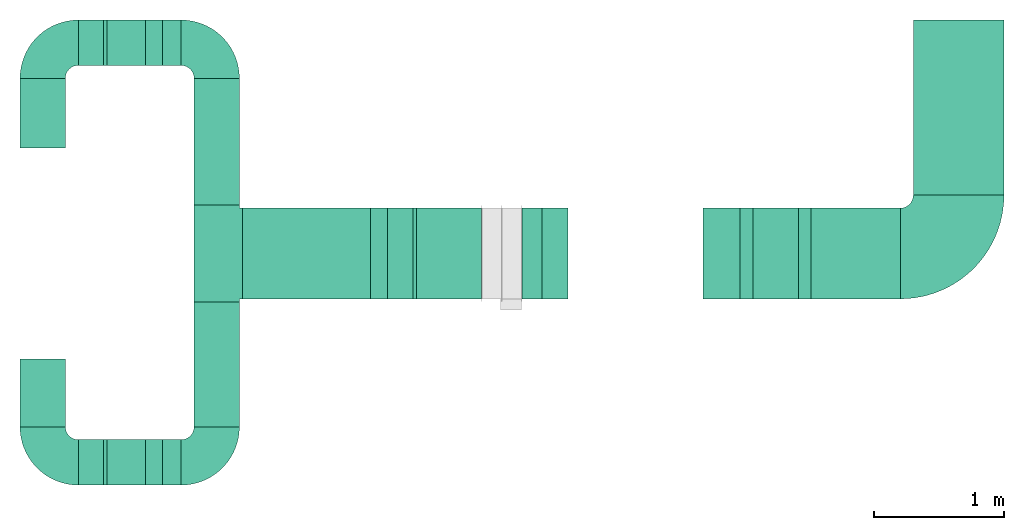
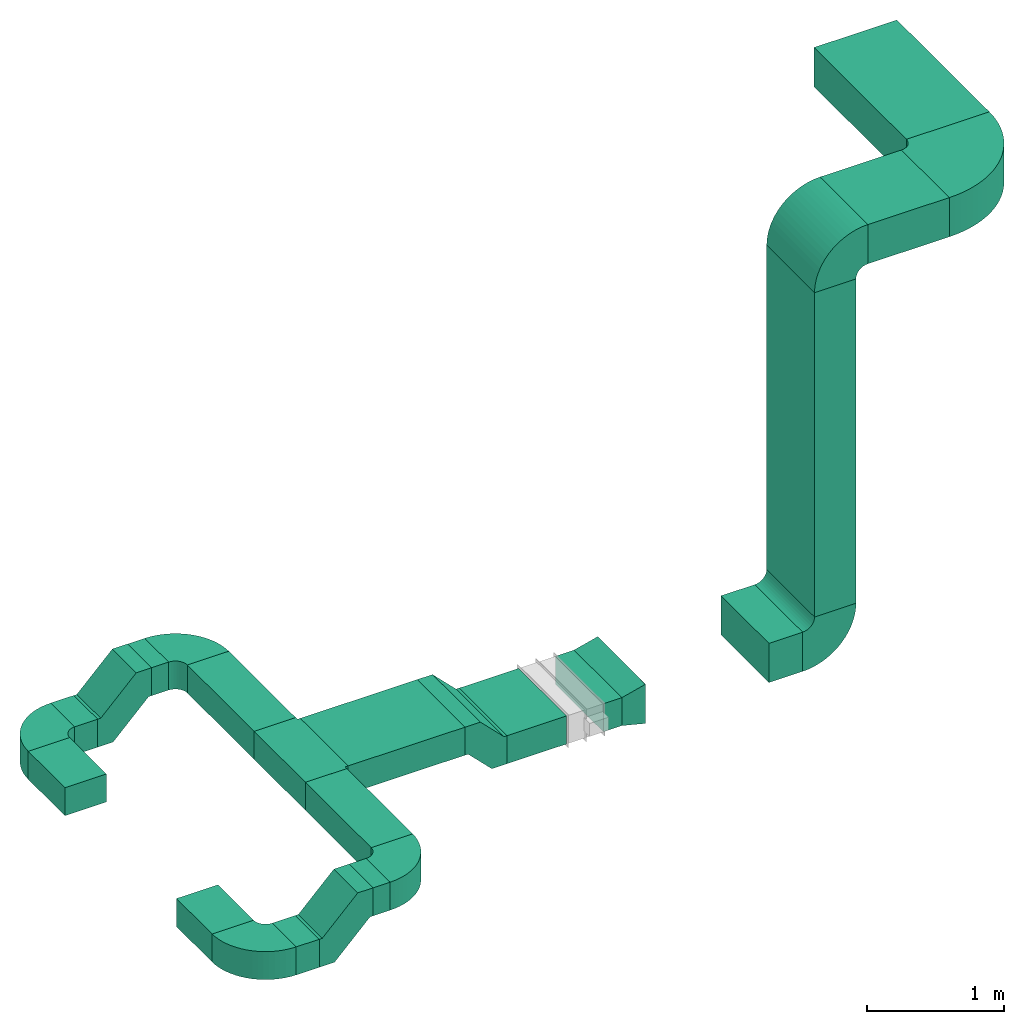
# One storey, part 1 of 2: 15 flow segments, 12 flow fittings.
"""IFC2X3 building model written with IfcOpenShell, lengths in millimetres."""

import ifcopenshell
import ifcopenshell.guid

model = None  # the IFC model being written
_history = None  # IfcOwnerHistory: only IFC2X3 demands one
_inside = {}  # id of a spatial element -> (the spatial element, [elements in it])
_under = {}  # id of a project, library or spatial element -> (it, [spatial elements below it])
_declared = {}  # id of a project -> (the project, [libraries it declares])
_typed = {}  # id of a type object -> (the type object, [elements of that type])
_made_of = {}  # id of a material, layer set ... -> (it, [elements and type objects made of it])


def new_model(schema):
    """Start an empty IFC model of exactly this schema.

    Asked for "IFC4X3", IfcOpenShell would pick the latest addendum, in which some entities
    have other attributes; the version numbers below select the first issue.
    IFC2X3 requires an IfcOwnerHistory on every rooted entity: one is made here for all.
    """
    global model, _history
    if schema == "IFC4X3":
        model = ifcopenshell.file(schema_version=(4, 3, 0, 0))
    else:
        model = ifcopenshell.file(schema=schema)
    _inside.clear()
    _under.clear()
    _declared.clear()
    _typed.clear()
    _made_of.clear()
    _history = None
    if model.schema == "IFC2X3":
        org = make("IfcOrganization", Name="unknown")
        user = make(
            "IfcPersonAndOrganization",
            ThePerson=make("IfcPerson", FamilyName="unknown"),
            TheOrganization=org,
        )
        app = make(
            "IfcApplication",
            ApplicationDeveloper=org,
            Version="unknown",
            ApplicationFullName="unknown",
            ApplicationIdentifier="unknown",
        )
        _history = make(
            "IfcOwnerHistory",
            OwningUser=user,
            OwningApplication=app,
            ChangeAction="ADDED",
            CreationDate=0,
        )
    return model


def make(cls, **values):
    """One entity of the class cls with the attributes given. An attribute that is None is left unset."""
    return model.create_entity(
        cls, **{name: value for name, value in values.items() if value is not None}
    )


def entity(cls, *values):
    """Any entity or typed value of the class cls, its attributes in the order of the schema. None: left unset."""
    e = model.create_entity(cls)
    for i, value in enumerate(values):
        if value is not None:
            e[i] = value
    return e


def rooted(cls, **values):
    """An entity with a GlobalId (a new one), such as an element, a storey or a relation."""
    return make(cls, GlobalId=ifcopenshell.guid.new(), OwnerHistory=_history, **values)


def si_unit(unit_type, name, prefix=None):
    """IfcSIUnit, for example si_unit("LENGTHUNIT", "METRE", prefix="MILLI")."""
    return make("IfcSIUnit", UnitType=unit_type, Prefix=prefix, Name=name)


def converted_unit(unit_type, name, factor, base, dimensions=None, offset=None):
    """IfcConversionBasedUnit, such as the inch: factor (a typed value) times the base unit."""
    return make(
        "IfcConversionBasedUnit"
        if offset is None
        else "IfcConversionBasedUnitWithOffset",
        ConversionOffset=offset,
        Dimensions=None
        if dimensions is None
        else entity("IfcDimensionalExponents", *dimensions),
        UnitType=unit_type,
        Name=name,
        ConversionFactor=make(
            "IfcMeasureWithUnit", ValueComponent=factor, UnitComponent=base
        ),
    )


def derived_unit(unit_type, elements):
    """IfcDerivedUnit: a product of units, each with its exponent."""
    return make(
        "IfcDerivedUnit",
        Elements=[
            make("IfcDerivedUnitElement", Unit=unit, Exponent=power)
            for unit, power in elements
        ],
        UnitType=unit_type,
    )


def assignment(units):
    """IfcUnitAssignment: the units of a project."""
    return None if units is None else make("IfcUnitAssignment", Units=units)


def point(xyz):
    """IfcCartesianPoint."""
    return None if xyz is None else make("IfcCartesianPoint", Coordinates=xyz)


def direction(xyz):
    """IfcDirection."""
    return None if xyz is None else make("IfcDirection", DirectionRatios=xyz)


def frame(location, z_axis=None, x_axis=None):
    """IfcAxis2Placement3D, a coordinate frame: its origin and axes. An axis left out is left unset."""
    return make(
        "IfcAxis2Placement3D",
        Location=point(location),
        Axis=direction(z_axis),
        RefDirection=direction(x_axis),
    )


def frame_2d(location, x_axis=None):
    """IfcAxis2Placement2D, a coordinate frame in the plane: its origin and x axis."""
    return make(
        "IfcAxis2Placement2D", Location=point(location), RefDirection=direction(x_axis)
    )


def origin():
    """The frame at (0, 0, 0) with its axes left unset."""
    return frame((0.0, 0.0, 0.0))


def origin_2d_with_axis():
    """The frame at (0, 0) in the plane with the x axis (1, 0) written out."""
    return frame_2d((0.0, 0.0), x_axis=(1.0, 0.0))


def place(relative_to, where):
    """IfcLocalPlacement: puts the frame where relative to a parent placement (None: the world)."""
    return make(
        "IfcLocalPlacement", PlacementRelTo=relative_to, RelativePlacement=where
    )


def context(
    kind, dimensions, precision=None, world=None, true_north=None, identifier=None
):
    """IfcGeometricRepresentationContext, for example the 3D "Model" context."""
    return make(
        "IfcGeometricRepresentationContext",
        ContextIdentifier=identifier,
        ContextType=kind,
        CoordinateSpaceDimension=dimensions,
        Precision=precision,
        WorldCoordinateSystem=world,
        TrueNorth=true_north,
    )


def subcontext(parent, identifier, kind, view, scale=None):
    """IfcGeometricRepresentationSubContext, for example "Body" below "Model"."""
    return make(
        "IfcGeometricRepresentationSubContext",
        ContextIdentifier=identifier,
        ContextType=kind,
        ParentContext=parent,
        TargetScale=scale,
        TargetView=view,
    )


def project(units=None, contexts=None):
    """IfcProject with its units and contexts."""
    return rooted(
        "IfcProject",
        Name="project",
        RepresentationContexts=contexts,
        UnitsInContext=assignment(units),
    )


def spatial(cls, under=None, at=None, **own):
    """A site, building, storey or space (cls), placed at a placement, below another one or the project."""
    s = rooted(cls, ObjectPlacement=at, **own)
    if under is not None:
        _under.setdefault(under.id(), (under, []))[1].append(s)
    return s


def polyline(points):
    """IfcPolyline through the points."""
    return make("IfcPolyline", Points=[point(p) for p in points])


def circle_curve(where, radius):
    """IfcCircle in the frame where."""
    return make("IfcCircle", Position=where, Radius=radius)


def parameter(value):
    """IfcParameterValue: where a trimmed curve begins or ends, as a parameter of its basis curve."""
    return model.create_entity("IfcParameterValue", value)


def trimmed(basis, trim1, trim2, sense, master):
    """IfcTrimmedCurve: the piece of a basis curve between two trims."""
    return make(
        "IfcTrimmedCurve",
        BasisCurve=basis,
        Trim1=trim1,
        Trim2=trim2,
        SenseAgreement=sense,
        MasterRepresentation=master,
    )


def segment(curve, same_sense, transition):
    """IfcCompositeCurveSegment."""
    return make(
        "IfcCompositeCurveSegment",
        Transition=transition,
        SameSense=same_sense,
        ParentCurve=curve,
    )


def composite_curve(segments, self_intersect=None):
    """IfcCompositeCurve: segments joined end to end."""
    return make("IfcCompositeCurve", Segments=segments, SelfIntersect=self_intersect)


def profile(cls, at=None, kind="AREA", **sizes):
    """A parametric profile (cls). Its sizes go by their IFC names, for example OverallWidth=200.0."""
    return make(cls, ProfileType=kind, Position=at, **sizes)


def rectangle(**sizes):
    """IfcRectangleProfileDef."""
    return profile("IfcRectangleProfileDef", **sizes)


def outline(outer, holes=None, kind="AREA"):
    """IfcArbitraryClosedProfileDef: a profile drawn as a closed curve; with holes, ...WithVoids."""
    if holes is None:
        return make("IfcArbitraryClosedProfileDef", ProfileType=kind, OuterCurve=outer)
    return make(
        "IfcArbitraryProfileDefWithVoids",
        ProfileType=kind,
        OuterCurve=outer,
        InnerCurves=holes,
    )


def extrude(swept, where, along, depth):
    """IfcExtrudedAreaSolid: the profile swept, set in the frame where, extruded along a direction by depth."""
    return make(
        "IfcExtrudedAreaSolid",
        SweptArea=swept,
        Position=where,
        ExtrudedDirection=direction(along),
        Depth=depth,
    )


def shape(context_of_items, identifier, shape_type, items):
    """IfcShapeRepresentation: the items that make up one representation, for example the "Body"."""
    return make(
        "IfcShapeRepresentation",
        ContextOfItems=context_of_items,
        RepresentationIdentifier=identifier,
        RepresentationType=shape_type,
        Items=items,
    )


def source(mapping_origin, context_of_items, identifier, shape_type, items):
    """IfcRepresentationMap: a shape defined once, which mapped items show again and again."""
    return make(
        "IfcRepresentationMap",
        MappingOrigin=mapping_origin,
        MappedRepresentation=shape(context_of_items, identifier, shape_type, items),
    )


def transform(
    local_origin,
    x_axis=None,
    y_axis=None,
    z_axis=None,
    scale=None,
    scale2=None,
    scale3=None,
    uniform=True,
):
    """IfcCartesianTransformationOperator3D, or its non-uniform kind. x_axis, y_axis, z_axis: its Axis1, 2, 3."""
    if uniform:
        return make(
            "IfcCartesianTransformationOperator3D",
            Axis1=direction(x_axis),
            Axis2=direction(y_axis),
            LocalOrigin=point(local_origin),
            Scale=scale,
            Axis3=direction(z_axis),
        )
    return make(
        "IfcCartesianTransformationOperator3DnonUniform",
        Axis1=direction(x_axis),
        Axis2=direction(y_axis),
        LocalOrigin=point(local_origin),
        Scale=scale,
        Axis3=direction(z_axis),
        Scale2=scale2,
        Scale3=scale3,
    )


def mapped(mapping_source, mapping_target):
    """IfcMappedItem: shows the shape of a source again, moved by a transform."""
    return make(
        "IfcMappedItem", MappingSource=mapping_source, MappingTarget=mapping_target
    )


def material(Name=None, Category=None):
    """IfcMaterial."""
    return make("IfcMaterial", Name=Name, Category=Category)


def made_of(thing, what):
    """Note that an element or type object is made of a material, layer set ...; save() writes the relation."""
    if what is not None:
        _made_of.setdefault(what.id(), (what, []))[1].append(thing)
    return thing


def type_object(cls, material=None, **own):
    """A type object (cls), such as IfcWallType, which elements share."""
    return made_of(rooted(cls, **own), material)


def type_shapes(of_type, sources):
    """Give a type object the sources (RepresentationMaps) that its elements show as mapped items."""
    of_type.RepresentationMaps = sources


def element(
    cls,
    number,
    at=None,
    inside=None,
    cuts=None,
    type_object=None,
    material=None,
    context=None,
    identifier="Body",
    shape_type=None,
    held_by="IfcProductDefinitionShape",
    body=None,
    shapes=None,
    **own,
):
    """One element of the class cls, such as IfcWall. Its Tag is "e" and its number.

    at: its placement. inside: the storey or other place that contains it. cuts: it is an
    opening in that element (IfcRelVoidsElement). A single representation is given by context,
    identifier, shape_type and body (its items); several are given by shapes. held_by: the class
    of the entity that holds the representations. save() writes the other relations.
    """
    e = rooted(cls, Tag="e%d" % number, ObjectPlacement=at, **own)
    if body is not None:
        shapes = [shape(context, identifier, shape_type, body)]
    if shapes is not None:
        e.Representation = make(held_by, Representations=shapes)
    if inside is not None:
        _inside.setdefault(inside.id(), (inside, []))[1].append(e)
    if cuts is not None:
        rooted(
            "IfcRelVoidsElement", RelatingBuildingElement=cuts, RelatedOpeningElement=e
        )
    if type_object is not None:
        _typed.setdefault(type_object.id(), (type_object, []))[1].append(e)
    return made_of(e, material)


def aggregate(whole, parts):
    """IfcRelAggregates: a whole, such as a stair, and the parts it consists of."""
    return rooted("IfcRelAggregates", RelatingObject=whole, RelatedObjects=parts)


def save(model, path):
    """Write the relations noted so far, then the file.

    IfcRelAggregates (storeys below a building ...), IfcRelContainedInSpatialStructure (elements
    in a storey), IfcRelDefinesByType, IfcRelAssociatesMaterial and IfcRelDeclares: one each for
    every whole, place, type object, material and project.
    """
    for whole, parts in _under.values():
        aggregate(whole, parts)
    for where, things in _inside.values():
        rooted(
            "IfcRelContainedInSpatialStructure",
            RelatedElements=things,
            RelatingStructure=where,
        )
    for kind, things in _typed.values():
        rooted("IfcRelDefinesByType", RelatedObjects=things, RelatingType=kind)
    for what, things in _made_of.values():
        rooted("IfcRelAssociatesMaterial", RelatedObjects=things, RelatingMaterial=what)
    for by, libraries in _declared.values():
        rooted("IfcRelDeclares", RelatingContext=by, RelatedDefinitions=libraries)
    model.write(path)


model = new_model("IFC2X3")

# Units and contexts
model_context = context("Model", 3, precision=0.01, world=origin(), true_north=direction((6.12303176911189e-17, 1.0)))
body_context = subcontext(model_context, "Body", "Model", "MODEL_VIEW")
ifc_project = project(units=[si_unit("LENGTHUNIT", "METRE", prefix="MILLI"), si_unit("AREAUNIT", "SQUARE_METRE"), si_unit("VOLUMEUNIT", "CUBIC_METRE"), converted_unit("PLANEANGLEUNIT", "DEGREE", entity("IfcRatioMeasure", 0.0174532925199433), si_unit("PLANEANGLEUNIT", "RADIAN"), dimensions=[0, 0, 0, 0, 0, 0, 0]), si_unit("MASSUNIT", "GRAM", prefix="KILO"), derived_unit("MASSDENSITYUNIT", [(si_unit("MASSUNIT", "GRAM", prefix="KILO"), 1), (si_unit("LENGTHUNIT", "METRE"), -3)]), si_unit("TIMEUNIT", "SECOND"), si_unit("FREQUENCYUNIT", "HERTZ"), si_unit("THERMODYNAMICTEMPERATUREUNIT", "DEGREE_CELSIUS"), derived_unit("THERMALTRANSMITTANCEUNIT", [(si_unit("MASSUNIT", "GRAM", prefix="KILO"), 1), (si_unit("THERMODYNAMICTEMPERATUREUNIT", "KELVIN"), -1), (si_unit("TIMEUNIT", "SECOND"), -3)]), derived_unit("VOLUMETRICFLOWRATEUNIT", [(si_unit("LENGTHUNIT", "METRE"), 3), (si_unit("TIMEUNIT", "SECOND"), -1)]), si_unit("ELECTRICCURRENTUNIT", "AMPERE"), si_unit("ELECTRICVOLTAGEUNIT", "VOLT"), si_unit("POWERUNIT", "WATT"), si_unit("FORCEUNIT", "NEWTON", prefix="KILO"), si_unit("ILLUMINANCEUNIT", "LUX"), si_unit("LUMINOUSFLUXUNIT", "LUMEN"), si_unit("LUMINOUSINTENSITYUNIT", "CANDELA"), derived_unit("USERDEFINED", [(si_unit("MASSUNIT", "GRAM", prefix="KILO"), -1), (si_unit("LENGTHUNIT", "METRE"), -2), (si_unit("TIMEUNIT", "SECOND"), 3), (si_unit("LUMINOUSFLUXUNIT", "LUMEN"), 1)]), derived_unit("LINEARVELOCITYUNIT", [(si_unit("LENGTHUNIT", "METRE"), 1), (si_unit("TIMEUNIT", "SECOND"), -1)]), si_unit("PRESSUREUNIT", "PASCAL"), derived_unit("USERDEFINED", [(si_unit("LENGTHUNIT", "METRE"), -2), (si_unit("MASSUNIT", "GRAM", prefix="KILO"), 1), (si_unit("TIMEUNIT", "SECOND"), -2)])], contexts=[model_context])

# Site, building, storey
site_placement = place(None, origin())
site = spatial("IfcSite", under=ifc_project, at=site_placement, CompositionType="ELEMENT")
building_placement = place(site_placement, origin())
building = spatial("IfcBuilding", under=site, at=building_placement, CompositionType="ELEMENT")
storey_placement = place(building_placement, frame((0.0, 0.0, 16000.0)))
storey = spatial("IfcBuildingStorey", under=building, at=storey_placement, Name="04 Roof", CompositionType="ELEMENT", Elevation=16000.0)

# Flow segments
duct_segment_type = type_object("IfcDuctSegmentType", Name="Rectangular Duct:Air", PredefinedType="NOTDEFINED")
flow_segment_1_placement = place(storey_placement, frame((24455.6615179764, -68016.2395851399, 1110.95052634352)))
element("IfcFlowSegment", 1, at=flow_segment_1_placement, inside=storey, type_object=duct_segment_type, Name="Rectangular Duct:Air", ObjectType="Rectangular Duct:Air", context=body_context, shape_type="SweptSolid", body=[
    extrude(rectangle(XDim=536.322509939068, YDim=349.999999999998, at=frame_2d((-8.64019966684282e-12, 0.0), x_axis=(1.0, 0.0))), frame((175.0, 268.161254969525, 0.0), z_axis=(0.0, 0.0, 1.0), x_axis=(0.0, -1.0, 0.0)), (0.0, 0.0, 1.0), 249.999999999999),
])
flow_segment_2_placement = place(storey_placement, frame((24455.6615179763, -70167.9433547427, 1110.95052634352)))
element("IfcFlowSegment", 2, at=flow_segment_2_placement, inside=storey, type_object=duct_segment_type, Name="Rectangular Duct:Air", ObjectType="Rectangular Duct:Air", context=body_context, shape_type="SweptSolid", body=[
    extrude(rectangle(XDim=521.70376960282, YDim=349.999999999998, at=origin_2d_with_axis()), frame((175.0, 260.85188480141, 0.0), z_axis=(0.0, 0.0, 1.0), x_axis=(0.0, 1.0, 0.0)), (0.0, 0.0, 1.0), 249.999999999999),
])
flow_segment_3_placement = place(storey_placement, frame((24905.6615179764, -67379.9170752009, 1110.95052634352)))
element("IfcFlowSegment", 3, at=flow_segment_3_placement, inside=storey, type_object=duct_segment_type, Name="Rectangular Duct:Air", ObjectType="Rectangular Duct:Air", context=body_context, shape_type="SweptSolid", body=[
    extrude(rectangle(XDim=194.397035506843, YDim=349.999999999998, at=frame_2d((-2.16715534406831e-12, -4.33431068813661e-12), x_axis=(1.0, 0.0))), frame((97.1985177534237, 175.0, 0.0)), (0.0, 0.0, 1.0), 249.999999999999),
])
flow_segment_4_placement = place(storey_placement, frame((24905.6615179763, -70617.9433547427, 1110.95052634352)))
element("IfcFlowSegment", 4, at=flow_segment_4_placement, inside=storey, type_object=duct_segment_type, Name="Rectangular Duct:Air", ObjectType="Rectangular Duct:Air", context=body_context, shape_type="SweptSolid", body=[
    extrude(rectangle(XDim=194.397035506869, YDim=349.999999999998, at=frame_2d((-2.16715534406831e-12, -4.33431068813661e-12), x_axis=(1.0, 0.0))), frame((97.1985177534324, 175.0, 0.0)), (0.0, 0.0, 1.0), 249.999999999999),
])
flow_segment_5_placement = place(storey_placement, frame((25798.4900708518, -70167.9433547427, 1410.95052634352)))
element("IfcFlowSegment", 5, at=flow_segment_5_placement, inside=storey, type_object=duct_segment_type, Name="Rectangular Duct:Air", ObjectType="Rectangular Duct:Air", context=body_context, shape_type="SweptSolid", body=[
    extrude(rectangle(XDim=961.703769602799, YDim=349.999999999998, at=frame_2d((-4.34852154285181e-12, 0.0), x_axis=(1.0, 0.0))), frame((175.0, 480.851884801395, 0.0), z_axis=(0.0, 0.0, 1.0), x_axis=(0.0, -1.0, 0.0)), (0.0, 0.0, 1.0), 249.999999999999),
])
flow_segment_6_placement = place(storey_placement, frame((25554.4119440765, -67379.9170752009, 1410.95052634352)))
element("IfcFlowSegment", 6, at=flow_segment_6_placement, inside=storey, type_object=duct_segment_type, Name="Rectangular Duct:Air", ObjectType="Rectangular Duct:Air", context=body_context, shape_type="SweptSolid", body=[
    extrude(rectangle(XDim=144.078126775314, YDim=349.999999999998, at=frame_2d((2.16715534406831e-12, 4.33431068813661e-12), x_axis=(1.0, 0.0))), frame((72.0390633876592, 175.0, 0.0), z_axis=(0.0, 0.0, 1.0), x_axis=(-1.0, 0.0, 0.0)), (0.0, 0.0, 1.0), 249.999999999999),
])
flow_segment_7_placement = place(storey_placement, frame((25554.4119440765, -70617.9433547427, 1410.95052634352)))
element("IfcFlowSegment", 7, at=flow_segment_7_placement, inside=storey, type_object=duct_segment_type, Name="Rectangular Duct:Air", ObjectType="Rectangular Duct:Air", context=body_context, shape_type="SweptSolid", body=[
    extrude(rectangle(XDim=144.078126775323, YDim=349.999999999998, at=frame_2d((2.16715534406831e-12, -4.33431068813661e-12), x_axis=(1.0, 0.0))), frame((72.0390633876592, 175.0, 0.0), z_axis=(0.0, 0.0, 1.0), x_axis=(-1.0, 0.0, 0.0)), (0.0, 0.0, 1.0), 249.999999999999),
])
flow_segment_8_placement = place(storey_placement, frame((25798.4900708518, -68456.2395851399, 1410.95052634352)))
element("IfcFlowSegment", 8, at=flow_segment_8_placement, inside=storey, type_object=duct_segment_type, Name="Rectangular Duct:Air", ObjectType="Rectangular Duct:Air", context=body_context, shape_type="SweptSolid", body=[
    extrude(rectangle(XDim=976.322509939072, YDim=349.999999999998, at=frame_2d((-8.66862137627322e-12, 0.0), x_axis=(1.0, 0.0))), frame((175.0, 488.161254969527, 0.0), z_axis=(0.0, 0.0, 1.0), x_axis=(0.0, -1.0, 0.0)), (0.0, 0.0, 1.0), 249.999999999999),
])
flow_segment_9_placement = place(storey_placement, frame((27514.4119440766, -69181.2395851399, 1210.95052634352)))
element("IfcFlowSegment", 9, at=flow_segment_9_placement, inside=storey, type_object=duct_segment_type, Name="Rectangular Duct:Air", ObjectType="Rectangular Duct:Air", context=body_context, shape_type="SweptSolid", body=[
    extrude(rectangle(XDim=502.633779032537, YDim=699.999999999997, at=frame_2d((0.0, 8.66862137627322e-12), x_axis=(1.0, 0.0))), frame((251.316889516268, 350.0, 0.0)), (0.0, 0.0, 1.0), 249.999999999999),
])
flow_segment_10_placement = place(storey_placement, frame((29724.3888768053, -69181.2395851399, 1160.95052634351)))
element("IfcFlowSegment", 10, at=flow_segment_10_placement, inside=storey, type_object=duct_segment_type, Name="Rectangular Duct:Air", ObjectType="Rectangular Duct:Air", context=body_context, shape_type="SweptSolid", body=[
    extrude(rectangle(XDim=285.0, YDim=699.999999999997, at=frame_2d((-2.1600499167107e-12, 8.66862137627322e-12), x_axis=(1.0, 0.0))), frame((142.500000000002, 350.0, 0.0)), (0.0, 0.0, 1.0), 349.999999999998),
])
flow_segment_11_placement = place(storey_placement, frame((30559.3888768053, -69181.23958514, 4605.0)))
element("IfcFlowSegment", 11, at=flow_segment_11_placement, inside=storey, type_object=duct_segment_type, Name="Rectangular Duct:Air", ObjectType="Rectangular Duct:Air", context=body_context, shape_type="SweptSolid", body=[
    extrude(rectangle(XDim=687.100686089119, YDim=699.999999999997, at=frame_2d((-2.1600499167107e-12, 8.66862137627322e-12), x_axis=(1.0, 0.0))), frame((343.550343044557, 350.0, 0.0), z_axis=(0.0, 0.0, 1.0), x_axis=(-1.0, 0.0, 0.0)), (0.0, 0.0, 1.0), 349.999999999998),
])
flow_segment_12_placement = place(storey_placement, frame((30109.3888768053, -69181.23958514, 1610.95052634351)))
element("IfcFlowSegment", 12, at=flow_segment_12_placement, inside=storey, type_object=duct_segment_type, Name="Rectangular Duct:Air", ObjectType="Rectangular Duct:Air", context=body_context, shape_type="SweptSolid", body=[
    extrude(rectangle(XDim=349.999999999998, YDim=699.999999999997, at=frame_2d((4.33431068813661e-12, 0.0), x_axis=(1.0, 0.0))), frame((175.0, 350.0, 0.0), z_axis=(0.0, 0.0, 1.0), x_axis=(-1.0, 0.0, 0.0)), (0.0, 0.0, 1.0), 2894.0494736565),
])
flow_segment_13_placement = place(storey_placement, frame((31346.4895628944, -68381.23958514, 4605.0)))
element("IfcFlowSegment", 13, at=flow_segment_13_placement, inside=storey, type_object=duct_segment_type, Name="Rectangular Duct:Air", ObjectType="Rectangular Duct:Air", context=body_context, shape_type="SweptSolid", body=[
    extrude(rectangle(XDim=1351.3225099391, YDim=700.000000000001, at=origin_2d_with_axis()), frame((350.0, 675.661254969554, 0.0), z_axis=(0.0, 0.0, 1.0), x_axis=(0.0, -1.0, 0.0)), (0.0, 0.0, 1.0), 349.999999999998),
])
flow_segment_14_placement = place(storey_placement, frame((28327.0457231092, -69181.23958514, 1210.95052634351)))
element("IfcFlowSegment", 14, at=flow_segment_14_placement, inside=storey, type_object=duct_segment_type, Name="Rectangular Duct:Air", ObjectType="Rectangular Duct:Air", context=body_context, shape_type="SweptSolid", body=[
    extrude(rectangle(XDim=156.151679204469, YDim=699.999999999997, at=frame_2d((-4.33431068813661e-12, 0.0), x_axis=(1.0, 0.0))), frame((78.0758396022303, 350.0, 0.0), z_axis=(0.0, 0.0, 1.0), x_axis=(-1.0, 0.0, 0.0)), (0.0, 0.0, 1.0), 249.999999999999),
])
flow_segment_15_placement = place(storey_placement, frame((26173.4900708518, -69181.2395851399, 1410.95052634352)))
element("IfcFlowSegment", 15, at=flow_segment_15_placement, inside=storey, type_object=duct_segment_type, Name="Rectangular Duct:Air", ObjectType="Rectangular Duct:Air", context=body_context, shape_type="SweptSolid", body=[
    extrude(rectangle(XDim=986.568482631552, YDim=699.999999999997, at=frame_2d((-4.32009983342141e-12, 0.0), x_axis=(1.0, 0.0))), frame((493.284241315771, 350.0, 0.0), z_axis=(0.0, 0.0, 1.0), x_axis=(-1.0, 0.0, 0.0)), (0.0, 0.0, 1.0), 249.999999999999),
])

# Flow fittings
duct_fitting_type_1 = type_object("IfcDuctFittingType", Name="Standard", PredefinedType="NOTDEFINED")
shared_shape_1 = source(origin(), body_context, "Body", "SweptSolid", [
    extrude(outline(polyline([(-227.176695296637, -275.0), (-98.2233047033632, -275.0), (201.776695296637, 25.0), (227.176695296637, 25.0), (227.176695296637, 275.0), (98.2233047033631, 275.0), (-201.776695296637, -25.0), (-227.176695296637, -25.0), (-227.176695296637, -275.0)])), frame((227.176695296643, 150.0, -175.0)), (0.0, 0.0, 1.0), 350.0),
])
type_shapes(duct_fitting_type_1, [shared_shape_1])
for number, where, z_axis, x_axis, name in (
    (16, (25100.0585534832, -70442.9433547427, 1235.95052634353), (0.0, -1.0, 0.0), (1.0, 0.0, 0.0), "M_Rectangular Offset - Plain - Flanged:Standard"),
    (17, (25100.0585534832, -67204.9170752009, 1235.95052634354), (0.0, -1.0, 0.0), (1.0, 0.0, 0.0), "M_Rectangular Offset - Plain - Flanged:Standard"),
):
    element("IfcFlowFitting", number, at=place(storey_placement, frame(where, z_axis=z_axis, x_axis=x_axis)), inside=storey, type_object=duct_fitting_type_1, Name=name, ObjectType="M_Rectangular Offset - Plain - Flanged:Standard", context=body_context, shape_type="MappedRepresentation", body=[
        mapped(shared_shape_1, transform((0.0, 0.0, 0.0), scale=1.0)),
    ])
duct_fitting_type_2 = type_object("IfcDuctFittingType", Name="Air_Elbow_Rect", PredefinedType="NOTDEFINED")
shared_shape_2 = source(origin(), body_context, "Body", "SweptSolid", [
    extrude(outline(composite_curve([segment(polyline([(-312.5, -137.5), (37.5, -137.5)]), True, "CONTINUOUS"), segment(trimmed(circle_curve(frame_2d((137.5, -137.5), x_axis=(0.0, 1.0)), 100.0), [parameter(0.0)], [parameter(90.0000000000001)], True, "PARAMETER"), False, "CONTINUOUS"), segment(polyline([(137.5, -37.4999999999998), (137.5, 312.5)]), True, "CONTINUOUS"), segment(trimmed(circle_curve(frame_2d((137.5, -137.5), x_axis=(0.0, 1.0)), 450.0), [parameter(0.0)], [parameter(90.0000000000001)], True, "PARAMETER"), True, "CONTINUOUS")], self_intersect=False)), frame((-137.499999999999, 137.5, -125.0), z_axis=(0.0, 0.0, 1.0), x_axis=(-1.0, 0.0, 0.0)), (0.0, 0.0, 1.0), 250.0),
])
type_shapes(duct_fitting_type_2, [shared_shape_2])
for number, where, z_axis, x_axis, name in (
    (18, (24630.6615179763, -70442.9433547427, 1235.95052634352), (0.0, 0.0, 1.0), (0.0, -1.0, 0.0), "elbow1_001:Air_Elbow_Rect"),
    (19, (24630.6615179764, -67204.9170752009, 1235.95052634352), (0.0, 0.0, 1.0), (-1.0, 0.0, 0.0), "elbow1_001:Air_Elbow_Rect"),
    (20, (25973.4900708518, -67204.9170752009, 1535.95052634352), (0.0, 0.0, 1.0), (0.0, 1.0, 0.0), "elbow1_001:Air_Elbow_Rect"),
):
    element("IfcFlowFitting", number, at=place(storey_placement, frame(where, z_axis=z_axis, x_axis=x_axis)), inside=storey, type_object=duct_fitting_type_2, Name=name, ObjectType="elbow1_001:Air_Elbow_Rect", context=body_context, shape_type="MappedRepresentation", body=[
        mapped(shared_shape_2, transform((0.0, 0.0, 0.0), scale=1.0)),
    ])
flow_fitting_1_placement = place(storey_placement, frame((25973.4900708518, -70442.9433547427, 1535.95052634352)))
element("IfcFlowFitting", 21, at=flow_fitting_1_placement, inside=storey, type_object=duct_fitting_type_2, Name="elbow1_001:Air_Elbow_Rect", ObjectType="elbow1_001:Air_Elbow_Rect", context=body_context, shape_type="MappedRepresentation", body=[
    mapped(shared_shape_2, transform((0.0, 0.0, 0.0), scale=1.0)),
])
duct_fitting_type_3 = type_object("IfcDuctFittingType", Name="Air_Rect", PredefinedType="NOTDEFINED")
shared_shape_3 = source(origin(), body_context, "Body", "SweptSolid", [
    extrude(outline(polyline([(-375.0, 81.2499999999999), (-375.0, -268.75), (375.0, -268.75), (375.0, 81.2500000000002), (350.0, 81.2500000000002), (350.0, 106.249999999999), (-350.0, 106.250000000001), (-350.0, 81.2499999999999), (-375.0, 81.2499999999999)])), frame((0.0, -93.75, -125.0), z_axis=(0.0, 0.0, -1.0), x_axis=(1.0, 0.0, 0.0)), (0.0, 0.0, -1.0), 250.0),
])
type_shapes(duct_fitting_type_3, [shared_shape_3])
flow_fitting_2_placement = place(storey_placement, frame((25973.4900708518, -68831.2395851399, 1535.95052634352), z_axis=(0.0, 0.0, 1.0), x_axis=(0.0, 1.0, 0.0)))
element("IfcFlowFitting", 22, at=flow_fitting_2_placement, inside=storey, type_object=duct_fitting_type_3, Name="1_001:Air_Rect", ObjectType="1_001:Air_Rect", context=body_context, shape_type="MappedRepresentation", body=[
    mapped(shared_shape_3, transform((0.0, 0.0, 0.0), scale=1.0)),
])
duct_fitting_type_4 = type_object("IfcDuctFittingType", Name="Standard", PredefinedType="NOTDEFINED")
shared_shape_4 = source(origin(), body_context, "Body", "SweptSolid", [
    extrude(outline(polyline([(-177.176695296637, -225.0), (-48.2233047033633, -225.0), (151.776695296637, -25.0), (177.176695296637, -25.0), (177.176695296637, 225.0), (48.223304703363, 225.0), (-151.776695296637, 25.0), (-177.176695296637, 25.0), (-177.176695296637, -225.0)])), frame((177.176695296643, 100.0, -350.0)), (0.0, 0.0, 1.0), 700.0),
])
type_shapes(duct_fitting_type_4, [shared_shape_4])
flow_fitting_3_placement = place(storey_placement, frame((27160.0585534833, -68831.2395851399, 1535.9505263435), z_axis=(0.0, 1.0, 0.0), x_axis=(1.0, 0.0, 0.0)))
element("IfcFlowFitting", 23, at=flow_fitting_3_placement, inside=storey, type_object=duct_fitting_type_4, Name="M_Rectangular Offset - Plain - Flanged:Standard", ObjectType="M_Rectangular Offset - Plain - Flanged:Standard", context=body_context, shape_type="MappedRepresentation", body=[
    mapped(shared_shape_4, transform((0.0, 0.0, 0.0), scale=1.0)),
])
duct_fitting_type_5 = type_object("IfcDuctFittingType", Name="Air_Elbow_Rect", PredefinedType="NOTDEFINED")
shared_shape_5 = source(origin(), body_context, "Body", "SweptSolid", [
    extrude(outline(composite_curve([segment(polyline([(-312.5, -137.5), (37.5, -137.5)]), True, "CONTINUOUS"), segment(trimmed(circle_curve(frame_2d((137.5, -137.5), x_axis=(0.0, 1.0)), 100.0), [parameter(0.0)], [parameter(90.0000000000001)], True, "PARAMETER"), False, "CONTINUOUS"), segment(polyline([(137.5, -37.4999999999998), (137.5, 312.5)]), True, "CONTINUOUS"), segment(trimmed(circle_curve(frame_2d((137.5, -137.5), x_axis=(0.0, 1.0)), 450.0), [parameter(0.0)], [parameter(90.0000000000001)], True, "PARAMETER"), True, "CONTINUOUS")], self_intersect=False)), frame((-137.499999999999, 137.5, -350.0), z_axis=(0.0, 0.0, 1.0), x_axis=(-1.0, 0.0, 0.0)), (0.0, 0.0, 1.0), 700.0),
])
type_shapes(duct_fitting_type_5, [shared_shape_5])
for number, where, z_axis, x_axis, name in (
    (24, (30284.3888768053, -68831.2395851399, 1335.95052634351), (0.0, -1.0, 0.0), (1.0, 0.0, 0.0), "elbow1_001:Air_Elbow_Rect"),
    (25, (30284.3888768053, -68831.23958514, 4780.0), (0.0, 1.0, 0.0), (0.0, 0.0, 1.0), "elbow1_001:Air_Elbow_Rect"),
):
    element("IfcFlowFitting", number, at=place(storey_placement, frame(where, z_axis=z_axis, x_axis=x_axis)), inside=storey, type_object=duct_fitting_type_5, Name=name, ObjectType="elbow1_001:Air_Elbow_Rect", context=body_context, shape_type="MappedRepresentation", body=[
        mapped(shared_shape_5, transform((0.0, 0.0, 0.0), scale=1.0)),
    ])
duct_fitting_type_6 = type_object("IfcDuctFittingType", Name="Air_Elbow_Rect", PredefinedType="NOTDEFINED")
shared_shape_6 = source(origin(), body_context, "Body", "SweptSolid", [
    extrude(outline(composite_curve([segment(polyline([(-575.0, -225.0), (125.0, -225.0)]), True, "CONTINUOUS"), segment(trimmed(circle_curve(frame_2d((225.0, -225.0), x_axis=(0.0, 1.0)), 100.0), [parameter(0.0)], [parameter(90.0000000000001)], True, "PARAMETER"), False, "CONTINUOUS"), segment(polyline([(225.0, -125.0), (225.0, 575.0)]), True, "CONTINUOUS"), segment(trimmed(circle_curve(frame_2d((225.0, -225.0), x_axis=(0.0, 1.0)), 800.0), [parameter(0.0)], [parameter(90.0)], True, "PARAMETER"), True, "CONTINUOUS")], self_intersect=False)), frame((-225.0, 225.0, -175.0), z_axis=(0.0, 0.0, 1.0), x_axis=(-1.0, 0.0, 0.0)), (0.0, 0.0, 1.0), 350.0),
])
type_shapes(duct_fitting_type_6, [shared_shape_6])
flow_fitting_4_placement = place(storey_placement, frame((31696.4895628944, -68831.23958514, 4780.0)))
element("IfcFlowFitting", 26, at=flow_fitting_4_placement, inside=storey, type_object=duct_fitting_type_6, Name="elbow1_001:Air_Elbow_Rect", ObjectType="elbow1_001:Air_Elbow_Rect", context=body_context, shape_type="MappedRepresentation", body=[
    mapped(shared_shape_6, transform((0.0, 0.0, 0.0), scale=1.0)),
])
ifc_material = material(Name="DF_Material1")
duct_fitting_type_7 = type_object("IfcDuctFittingType", Name="Air_LRD", PredefinedType="NOTDEFINED", material=ifc_material)
shared_shape_7 = source(origin(), body_context, "Body", "SweptSolid", [
    extrude(rectangle(XDim=1.99999999999999, YDim=700.0, at=origin_2d_with_axis()), frame((199.0, 0.0, -125.0), z_axis=(0.0, 0.0, 1.0), x_axis=(-1.0, 0.0, 0.0)), (0.0, 0.0, 1.0), 250.0),
    extrude(rectangle(XDim=2.0, YDim=700.0, at=origin_2d_with_axis()), frame((1.0, 0.0, -175.0), z_axis=(0.0, 0.0, 1.0), x_axis=(-1.0, 0.0, 0.0)), (0.0, 0.0, 1.0), 350.0),
    extrude(outline(polyline([(-139.457984395889, -145.5213750218), (66.6972968849936, -145.5213750218), (127.331203144073, 97.0142500145336), (-54.5705156331777, 194.028500029067), (-139.457984395889, -145.5213750218)])), frame((100.0, -350.0, 0.0), z_axis=(0.0, 1.0, 0.0), x_axis=(0.970142500145336, 0.0, -0.242535625036317)), (0.0, 0.0, 1.0), 700.0),
])
type_shapes(duct_fitting_type_7, [shared_shape_7])
flow_fitting_5_placement = place(storey_placement, frame((28683.1974023136, -68831.23958514, 1335.95052634351), z_axis=(0.0, 0.0, 1.0), x_axis=(-1.0, 0.0, 0.0)))
element("IfcFlowFitting", 27, at=flow_fitting_5_placement, inside=storey, type_object=duct_fitting_type_7, material=ifc_material, Name="LDR:Air", ObjectType="LDR:Air_LRD", context=body_context, shape_type="MappedRepresentation", body=[
    mapped(shared_shape_7, transform((0.0, 0.0, 0.0), scale=1.0)),
])

save(model, "model.ifc")
